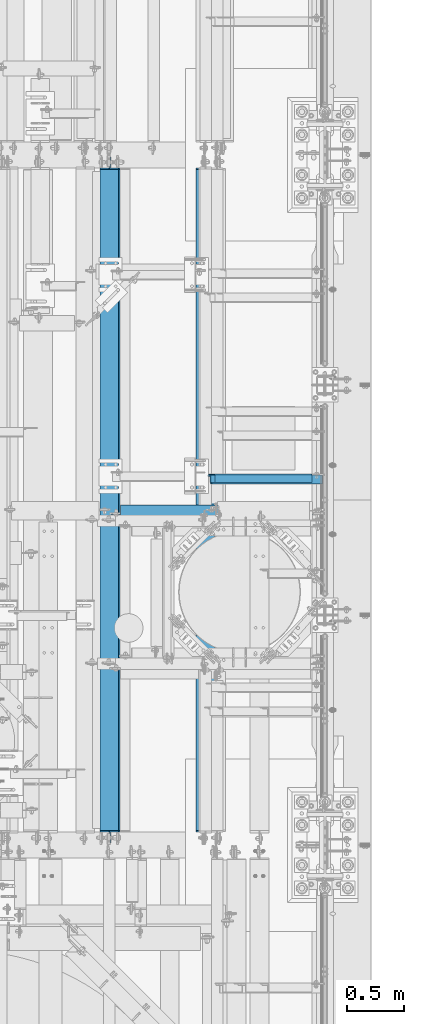
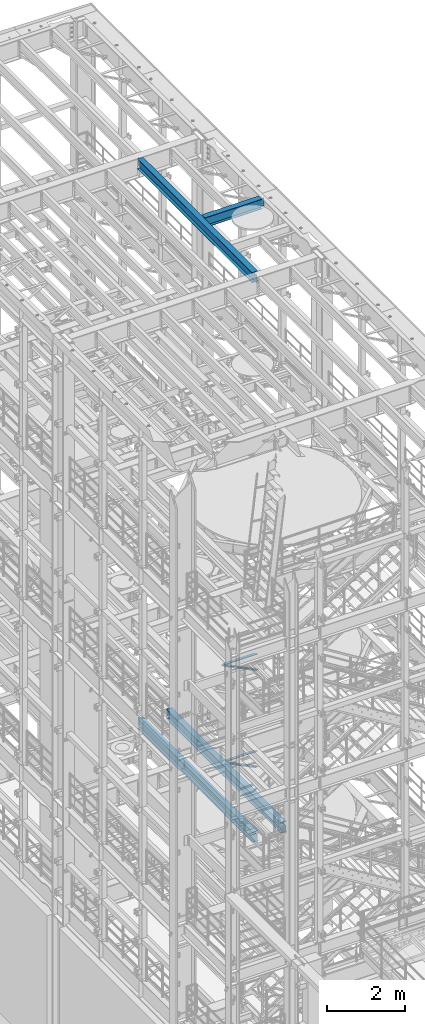
# One storey, part 1032 of 1876: 6 beams, 2 members, 8 elements without a shape of their own.
"""IFC2X3 building model written with IfcOpenShell, lengths in millimetres."""

from ifc_helpers import new_model, si_unit, frame, origin_with_axes, place, context, subcontext, project, spatial, faceted_brep, material, type_object, element, aggregate, save


model = new_model("IFC2X3")

# Units and contexts
model_context = context("Model", 3, precision=1e-05, world=origin_with_axes())
body_context = subcontext(model_context, "Body", "Model", "MODEL_VIEW")
ifc_project = project(units=[si_unit("LENGTHUNIT", "METRE", prefix="MILLI"), si_unit("AREAUNIT", "SQUARE_METRE"), si_unit("VOLUMEUNIT", "CUBIC_METRE"), si_unit("MASSUNIT", "GRAM", prefix="KILO"), si_unit("TIMEUNIT", "SECOND"), si_unit("PLANEANGLEUNIT", "RADIAN"), si_unit("SOLIDANGLEUNIT", "STERADIAN"), si_unit("THERMODYNAMICTEMPERATUREUNIT", "DEGREE_CELSIUS"), si_unit("LUMINOUSINTENSITYUNIT", "LUMEN")], contexts=[model_context])

# Site, building, storey
site_placement = place(None, origin_with_axes())
site = spatial("IfcSite", under=ifc_project, at=site_placement, CompositionType="ELEMENT")
building_placement = place(site_placement, origin_with_axes())
building = spatial("IfcBuilding", under=site, at=building_placement, Name="Undefined", CompositionType="ELEMENT")
storey_placement = place(building_placement, origin_with_axes())
storey = spatial("IfcBuildingStorey", under=building, at=storey_placement, Name="Undefined", CompositionType="ELEMENT", Elevation=0.0)

# Assembly, member
assembly_1_placement = place(storey_placement, origin_with_axes())
assembly_1 = element("IfcElementAssembly", 1, at=assembly_1_placement, inside=storey, AssemblyPlace="NOTDEFINED", PredefinedType="RIGID_FRAME")
ifc_material_1 = material(Name="STEEL/A36")
member_type = type_object("IfcMemberType", Name="L3X3X3/8", PredefinedType="NOTDEFINED")
member_1_placement = place(assembly_1_placement, frame((6549.21887719362, 4752.975, 5096.54580110531), z_axis=(0.0, -1.0, 0.0), x_axis=(0.899060338191213, 0.0, -0.437824746093117)))
member_1 = element("IfcMember", 2, at=member_1_placement, type_object=member_type, material=ifc_material_1, ObjectType="L3X3X3/8", context=body_context, shape_type="Brep", body=[
    faceted_brep([(54.7652293632691, 38.0999999999885, -38.1000000000004), (54.7652293632691, 38.0999999999885, 38.1000000000004), (1150.37468125874, 38.1000000001977, 38.1000000000004), (1150.37468125874, 38.1000000001977, -38.1000000000004), (54.7652293632686, 28.5749999999944, 38.1000000000004), (1150.37468125873, 28.5750000002035, 38.1000000000004), (54.7652293632686, 28.5749999999944, -28.5749999999998), (1150.37468125873, 28.5750000002035, -28.5749999999998), (54.7652293632682, -38.0999999999685, -28.5749999999998), (1150.37468125873, -38.0999999997593, -28.5749999999998), (54.7652293632682, -38.0999999999685, -38.1000000000004), (1150.37468125873, -38.0999999997593, -38.1000000000004)], [[[0, 1, 2, 3]], [[1, 4, 5, 2]], [[4, 6, 7, 5]], [[6, 8, 9, 7]], [[8, 10, 11, 9]], [[10, 0, 3, 11]], [[5, 7, 9, 11, 3, 2]], [[10, 8, 6, 4, 1, 0]]]),
])
aggregate(assembly_1, [member_1])

assembly_2_placement = place(storey_placement, origin_with_axes())
assembly_2 = element("IfcElementAssembly", 3, at=assembly_2_placement, inside=storey, AssemblyPlace="NOTDEFINED", PredefinedType="RIGID_FRAME")
member_2_placement = place(assembly_2_placement, frame((6536.16116201617, 4752.975, 8132.02232402439), z_axis=(0.0, -1.0, 0.0), x_axis=(0.894427191199916, 0.0, -0.447213595099958)))
member_2 = element("IfcMember", 4, at=member_2_placement, type_object=member_type, material=ifc_material_1, ObjectType="L3X3X3/8", context=body_context, shape_type="Brep", body=[
    faceted_brep([(78.0946740306676, 38.1000000000076, -38.0999999999999), (78.0946740306676, 38.1000000000076, 38.0999999999999), (1170.5326724749, 38.0999999997912, 38.0999999999999), (1170.5326724749, 38.0999999997912, -38.0999999999999), (78.0946740306676, 28.5750000000025, 38.0999999999999), (1170.5326724749, 28.5749999997861, 38.0999999999999), (78.0946740306676, 28.5750000000025, -28.5749999999998), (1170.5326724749, 28.5749999997861, -28.5749999999998), (78.0946740306667, -38.1000000000367, -28.5749999999998), (1170.5326724749, -38.1000000002532, -28.5749999999998), (78.0946740306667, -38.1000000000367, -38.0999999999999), (1170.5326724749, -38.1000000002532, -38.0999999999999)], [[[0, 1, 2, 3]], [[1, 4, 5, 2]], [[4, 6, 7, 5]], [[6, 8, 9, 7]], [[8, 10, 11, 9]], [[10, 0, 3, 11]], [[5, 7, 9, 11, 3, 2]], [[10, 8, 6, 4, 1, 0]]]),
])
aggregate(assembly_2, [member_2])

# Assembly, beam
assembly_3_placement = place(storey_placement, origin_with_axes())
assembly_3 = element("IfcElementAssembly", 5, at=assembly_3_placement, inside=storey, Name="BEAM", AssemblyPlace="NOTDEFINED", PredefinedType="RIGID_FRAME")
ifc_material_2 = material(Name="STEEL/A992")
beam_type_1 = type_object("IfcBeamType", Name="W12X26", PredefinedType="NOTDEFINED")
beam_1_placement = place(assembly_3_placement, frame((5715.0, 4444.99920043945, 22399.625), z_axis=(0.0, 0.0, 1.0), x_axis=(1.0, 0.0, 0.0)))
beam_1 = element("IfcBeam", 6, at=beam_1_placement, type_object=beam_type_1, material=ifc_material_2, Name="BEAM", ObjectType="W12X26", context=body_context, shape_type="Brep", body=[
    faceted_brep([(1789.90625, -3.17500000000018, -146.049999999999), (1789.90625, -82.5500000000002, -146.049999999999), (1789.90625, -82.5500000000002, -155.575000000001), (1789.90625, 82.5500000000002, -155.575000000001), (1789.90625, 82.5500000000002, -146.049999999999), (1789.90625, 3.17500000000018, -146.049999999999), (1789.90625, 3.17500000000018, -142.874999809264), (1789.90625, -3.17500000000018, -142.874999809264), (1790.87297992259, 3.17500000000018, -138.014920291218), (1790.87297992259, -3.17500000000018, -138.014920291218), (1793.62599382307, 3.17500000000018, -133.894743823064), (1793.62599382307, -3.17500000000018, -133.894743823064), (1797.74617029122, 3.17500000000018, -131.141729922587), (1797.74617029122, -3.17500000000018, -131.141729922587), (1802.60624980926, 3.17500000000018, -130.174999999999), (1802.60624980926, -3.17500000000018, -130.174999999999), (1885.15625, -3.17500000000018, -130.174999999999), (1885.15625, 3.17500000000018, -130.174999999999), (98.4250000000029, 3.17500000000018, 146.049999999999), (98.4250000000002, 82.5500000000002, 146.049999999999), (1777.20625, 82.5500000000002, 146.049999999999), (1777.20625, 3.17500000000018, 146.049999999999), (98.4250000000002, -3.17500000000018, -142.874999809268), (98.4250000000002, 3.17500000000018, -142.874999809268), (98.4250000000029, 3.17500000000018, -146.049999999999), (98.4250000000002, 82.5500000000002, -146.049999999999), (98.4250000000002, 82.5500000000002, -155.575000000001), (98.4250000000002, -82.5500000000002, -155.575000000001), (98.4250000000002, -82.5500000000002, -146.049999999999), (98.4250000000029, -3.17500000000018, -146.049999999999), (97.4582700774126, -3.17500000000018, -138.014920291222), (97.4582700774126, 3.17500000000018, -138.014920291222), (94.7052561769342, -3.17500000000018, -133.894743823068), (94.7052561769342, 3.17500000000018, -133.894743823068), (90.5850797087805, -3.17500000000018, -131.14172992259), (90.5850797087805, 3.17500000000018, -131.14172992259), (85.725000190735, -3.17500000000018, -130.175000000003), (85.725000190735, 3.17500000000018, -130.175000000003), (15.875, -3.17500000000018, -130.175000000003), (15.875, 3.17500000000018, -130.175000000003), (15.875, -3.17500000000018, 117.474999999999), (15.875, 3.17500000000018, 117.474999999999), (85.725000190735, -3.17500000000018, 117.474999999999), (85.725000190735, 3.17500000000018, 117.474999999999), (90.5850797087805, -3.17500000000018, 118.441729922586), (90.5850797087805, 3.17500000000018, 118.441729922586), (94.7052561769342, -3.17500000000018, 121.194743823064), (94.7052561769342, 3.17500000000018, 121.194743823064), (97.4582700774126, -3.17500000000018, 125.314920291217), (97.4582700774126, 3.17500000000018, 125.314920291217), (98.4250000000002, -3.17500000000018, 130.174999809264), (98.4250000000002, 3.17500000000018, 130.174999809264), (98.4250000000002, -82.5500000000002, 155.575000000001), (98.4250000000002, 82.5500000000002, 155.575000000001), (98.4250000000029, -3.17500000000018, 146.049999999999), (98.4250000000002, -82.5500000000002, 146.049999999999), (1777.20625, -3.17500000000018, 146.049999999999), (1777.20625, -82.5500000000002, 146.049999999999), (1777.20625, -82.5500000000002, 155.575000000001), (1777.20625, 82.5500000000002, 155.575000000001), (1777.20625, -3.17500000000018, 130.174999809267), (1777.20625, 3.17500000000018, 130.174999809267), (1778.17297992259, -3.17500000000018, 125.314920291221), (1778.17297992259, 3.17500000000018, 125.314920291221), (1780.92599382307, -3.17500000000018, 121.194743823067), (1780.92599382307, 3.17500000000018, 121.194743823067), (1785.04617029122, -3.17500000000018, 118.44172992259), (1785.04617029122, 3.17500000000018, 118.44172992259), (1789.90624980926, -3.17500000000018, 117.475000000002), (1789.90624980926, 3.17500000000018, 117.475000000002), (1885.15625, -3.17500000000018, 117.475000000002), (1885.15625, 3.17500000000018, 117.475000000002)], [[[0, 1, 2, 3, 4, 5, 6, 7]], [[7, 6, 8, 9]], [[9, 8, 10, 11]], [[11, 10, 12, 13]], [[13, 12, 14, 15]], [[16, 15, 14, 17]], [[18, 19, 20, 21]], [[22, 23, 24, 25, 26, 27, 28, 29]], [[30, 31, 23, 22]], [[32, 33, 31, 30]], [[34, 35, 33, 32]], [[36, 37, 35, 34]], [[38, 39, 37, 36]], [[40, 41, 39, 38]], [[42, 43, 41, 40]], [[44, 45, 43, 42]], [[46, 47, 45, 44]], [[48, 49, 47, 46]], [[50, 51, 49, 48]], [[52, 53, 19, 18, 51, 50, 54, 55]], [[55, 54, 56, 57]], [[52, 55, 57, 58]], [[53, 52, 58, 59]], [[19, 53, 59, 20]], [[58, 57, 56, 60, 61, 21, 20, 59]], [[62, 63, 61, 60]], [[64, 65, 63, 62]], [[66, 67, 65, 64]], [[68, 69, 67, 66]], [[70, 71, 69, 68]], [[71, 70, 16, 17]], [[12, 10, 8, 6, 5, 24, 23, 31, 33, 35, 37, 39, 41, 43, 45, 47, 49, 51, 18, 21, 61, 63, 65, 67, 69, 71, 17, 14]], [[25, 24, 5, 4]], [[26, 25, 4, 3]], [[27, 26, 3, 2]], [[28, 27, 2, 1]], [[29, 28, 1, 0]], [[70, 68, 66, 64, 62, 60, 56, 54, 50, 48, 46, 44, 42, 40, 38, 36, 34, 32, 30, 22, 29, 0, 7, 9, 11, 13, 15, 16]]]),
])
aggregate(assembly_3, [beam_1])

assembly_4_placement = place(storey_placement, origin_with_axes())
assembly_4 = element("IfcElementAssembly", 7, at=assembly_4_placement, inside=storey, Name="BEAM", AssemblyPlace="NOTDEFINED", PredefinedType="RIGID_FRAME")
beam_2_placement = place(assembly_4_placement, frame((5715.0, 1524.0, 22399.625), z_axis=(0.0, 0.0, 1.0), x_axis=(0.0, 1.0, 0.0)))
beam_2 = element("IfcBeam", 8, at=beam_2_placement, type_object=beam_type_1, material=ifc_material_2, Name="BEAM", ObjectType="W12X26", context=body_context, shape_type="Brep", body=[
    faceted_brep([(19.8437512414296, -3.17500000000109, -130.175), (19.8437487585795, 3.17499999999927, -130.175), (102.393750190735, 3.17500000000018, -130.174999999999), (102.393750190735, -3.17500000000018, -130.174999999999), (107.25382970878, 3.17500000000018, -131.141729922587), (107.25382970878, -3.17500000000018, -131.141729922587), (111.374006176934, 3.17500000000018, -133.894743823064), (111.374006176934, -3.17500000000018, -133.894743823064), (114.127020077412, 3.17500000000018, -138.014920291218), (114.127020077412, -3.17500000000018, -138.014920291218), (115.09375, -3.17500000000018, -142.874999809264), (115.09375, 3.17500000000018, -142.874999809264), (115.09375, 3.17500000000018, -146.05), (115.09375, 82.5500000000002, -146.05), (115.09375, 82.5500000000002, -155.575000000001), (115.09375, -82.5500000000002, -155.575000000001), (115.09375, -82.5500000000002, -146.05), (115.09375, -3.17500000000018, -146.05), (5968.20624911051, 82.55, 146.049999999999), (5968.20625, 3.17499999999995, 146.05), (127.79375, 3.17500000000018, 146.05), (127.793782276814, 82.5500000000102, 146.05), (115.09378246755, -3.17499999999654, 117.474999999999), (115.093782467549, 3.17500000000382, 117.474999999999), (19.8437487585795, 3.17499999999927, 117.474999999999), (19.8437512414296, -3.17500000000109, 117.474999999999), (119.953861985596, -3.17499999999654, 118.441729922587), (119.953861985596, 3.17500000000382, 118.441729922587), (124.074038453751, -3.17499999999654, 121.194743823065), (124.074038453751, 3.17500000000382, 121.194743823065), (126.82705235423, -3.17499999999654, 125.314920291219), (126.827052354229, 3.17500000000473, 125.314920291219), (127.793782276818, -3.17499999999654, 130.174999809265), (127.793782276817, 3.17500000000382, 130.174999809265), (5968.20625, -82.5500000000002, 155.575000000001), (5968.20625, 82.5500000000002, 155.575000000001), (127.793782276814, 82.5500000000102, 155.575), (127.793782276821, -82.5500000000029, 155.575), (5968.20624911051, -82.55, 146.049999999999), (127.793782276821, -82.5500000000029, 146.05), (5968.20625, -3.17499999999995, 146.05), (127.79375, -3.17500000000018, 146.05), (5968.20625, -3.17500000000018, 130.174999809267), (5968.20625, 3.17500000000018, 130.174999809267), (5969.17297992259, -3.17500000000018, 125.314920291221), (5969.17297992259, 3.17500000000018, 125.314920291221), (5971.92599382307, -3.17500000000018, 121.194743823067), (5971.92599382307, 3.17500000000018, 121.194743823067), (5976.04617029122, -3.17500000000018, 118.44172992259), (5976.04617029122, 3.17500000000018, 118.44172992259), (5980.90624980927, -3.17500000000018, 117.475000000002), (5980.90624980927, 3.17500000000018, 117.475000000002), (6076.15625, -3.17500000000018, 117.475000000002), (6076.15625, 3.17500000000018, 117.475000000002), (6076.15625, -3.17499999999995, -130.174999999996), (6076.15625, 3.17499999999995, -130.174999999996), (5993.60624980927, -3.17500000000018, -130.174999999999), (5993.60624980927, 3.17500000000018, -130.174999999999), (5988.74617029122, -3.17500000000018, -131.141729922587), (5988.74617029122, 3.17500000000018, -131.141729922587), (5984.62599382307, -3.17500000000018, -133.894743823064), (5984.62599382307, 3.17500000000018, -133.894743823064), (5981.87297992259, -3.17500000000018, -138.014920291218), (5981.87297992259, 3.17500000000018, -138.014920291218), (5980.90625, -3.17500000000018, -142.874999809264), (5980.90625, 3.17500000000018, -142.874999809264), (5980.90625, -3.17499999999995, -146.05), (5980.90625, -82.5500000000002, -146.049999999999), (5980.90625, -82.5500000000002, -155.575000000001), (5980.90625, 82.5500000000002, -155.575000000001), (5980.90625, 82.5500000000002, -146.049999999999), (5980.90625, 3.17499999999995, -146.05)], [[[0, 1, 2, 3]], [[3, 2, 4, 5]], [[5, 4, 6, 7]], [[7, 6, 8, 9]], [[10, 11, 12, 13, 14, 15, 16, 17]], [[9, 8, 11, 10]], [[18, 19, 20, 21]], [[22, 23, 24, 25]], [[26, 27, 23, 22]], [[28, 29, 27, 26]], [[30, 31, 29, 28]], [[32, 33, 31, 30]], [[34, 35, 36, 37]], [[38, 34, 37, 39]], [[40, 38, 39, 41]], [[37, 36, 21, 20, 33, 32, 41, 39]], [[35, 18, 21, 36]], [[34, 38, 40, 42, 43, 19, 18, 35]], [[44, 45, 43, 42]], [[46, 47, 45, 44]], [[48, 49, 47, 46]], [[50, 51, 49, 48]], [[52, 53, 51, 50]], [[53, 52, 54, 55]], [[54, 56, 57, 55]], [[58, 59, 57, 56]], [[60, 61, 59, 58]], [[62, 63, 61, 60]], [[64, 65, 63, 62]], [[66, 67, 68, 69, 70, 71, 65, 64]], [[67, 66, 17, 16]], [[68, 67, 16, 15]], [[69, 68, 15, 14]], [[70, 69, 14, 13]], [[71, 70, 13, 12]], [[6, 4, 2, 1, 24, 23, 27, 29, 31, 33, 20, 19, 43, 45, 47, 49, 51, 53, 55, 57, 59, 61, 63, 65, 71, 12, 11, 8]], [[25, 24, 1, 0]], [[66, 64, 62, 60, 58, 56, 54, 52, 50, 48, 46, 44, 42, 40, 41, 32, 30, 28, 26, 22, 25, 0, 3, 5, 7, 9, 10, 17]]]),
])
aggregate(assembly_4, [beam_2])

assembly_5_placement = place(storey_placement, origin_with_axes())
assembly_5 = element("IfcElementAssembly", 9, at=assembly_5_placement, inside=storey, Name="ANGLE", AssemblyPlace="NOTDEFINED", PredefinedType="RIGID_FRAME")
beam_type_2 = type_object("IfcBeamType", Name="L3X3X3/8", PredefinedType="NOTDEFINED")
beam_3_placement = place(assembly_5_placement, frame((6553.19999999857, 4762.5, 8115.3), z_axis=(0.0, -1.0, 0.0), x_axis=(1.0, 0.0, 0.0)))
beam_3 = element("IfcBeam", 10, at=beam_3_placement, type_object=beam_type_2, material=ifc_material_1, Name="ANGLE", ObjectType="L3X3X3/8", context=body_context, shape_type="Brep", body=[
    faceted_brep([(950.913000303442, 28.5749999999998, -28.5749999999998), (950.913001170238, 28.5749999999998, 38.0999999999999), (52.3870335430847, 28.5750001907327, 38.0999999999858), (52.3869956588824, 28.5749999999955, -28.5750000000007), (950.913001170238, 38.1000000000004, 38.0999999999999), (52.387033543122, 38.0999999999985, 38.0999999999858), (15.8749936676099, 28.5749999999989, -28.5750000000007), (15.8749999382144, 28.5750001907327, -38.0999999999999), (3.17500012894925, 15.8750003814675, -38.0999999999999), (3.17500032897624, 15.8750003814675, -28.5749999999998), (52.3870393343063, 28.5750001907327, -38.1000000000149), (52.3869953826566, 38.0999999999954, -38.0999999999985), (950.913000179614, 38.1000000000004, -38.0999999999999), (950.913000303442, 12.6999992370611, -28.5749999999998), (950.913000179614, 12.6999992370611, -38.0999999999999), (1027.90624828928, 12.6999992370611, -28.5749999999998), (1027.90624816545, 12.6999992370611, -38.0999999999999), (1059.65624828928, -19.0500007629389, -28.5749999999998), (1059.65624816545, -19.0500007629389, -38.0999999999999), (1059.65625000143, -38.1000000000004, -28.5749999999998), (1059.65625000143, -38.1000000000004, -38.0999999999999), (3.17499999075153, -38.0999999999985, -28.5749999999998), (3.17499999075153, -38.0999999999985, -38.0999999999999), (3.17500012894925, 3.17500152587672, -38.0999999999999), (3.17500032897624, 3.17500152587672, -28.5749999999998)], [[[0, 1, 2, 3]], [[1, 4, 5, 2]], [[6, 7, 8, 9]], [[3, 10, 7, 6]], [[2, 5, 11, 10, 3]], [[4, 12, 11, 5]], [[1, 0, 13, 14, 12, 4]], [[15, 16, 14, 13]], [[16, 15, 17, 18]], [[18, 17, 19, 20]], [[20, 19, 21, 22]], [[8, 7, 10, 11, 12, 14, 16, 18, 20, 22, 23]], [[9, 8, 23, 24]], [[19, 17, 15, 13, 0, 3, 6, 9, 24, 21]], [[23, 22, 21, 24]]]),
])
aggregate(assembly_5, [beam_3])

assembly_6_placement = place(storey_placement, origin_with_axes())
assembly_6 = element("IfcElementAssembly", 11, at=assembly_6_placement, inside=storey, Name="ANGLE", AssemblyPlace="NOTDEFINED", PredefinedType="RIGID_FRAME")
beam_4_placement = place(assembly_6_placement, frame((6489.7, 4762.5, 5092.7), z_axis=(0.0, -1.0, 0.0), x_axis=(1.0, 0.0, 0.0)))
beam_4 = element("IfcBeam", 12, at=beam_4_placement, type_object=beam_type_2, material=ifc_material_1, Name="ANGLE", ObjectType="L3X3X3/8", context=body_context, shape_type="Brep", body=[
    faceted_brep([(1014.41300030201, 28.5749999999998, -28.5749999999998), (1014.41300116881, 28.5749999999998, 38.1000000000004), (160.337055571042, 28.5749999999998, 38.1000000000004), (160.337055570792, 28.5749999999998, -28.5749999999998), (1014.41300116881, 38.1000000000004, 38.1000000000004), (160.337388892724, 38.1000000000004, 38.1000000000004), (98.4249977111795, 26.9870083759042, -28.5749999999998), (98.4249977111795, 26.9870093950822, -38.1000000000004), (79.3749984741189, 7.93701015802071, -38.1000000000004), (79.3749984741189, 7.93700913884368, -28.5749999999998), (160.336999999974, 26.9870083759042, -28.5749999999998), (160.336999999974, 26.9870093950822, -38.1000000000004), (160.337388892438, 38.1000000000004, -38.1000000000004), (1014.41300017818, 38.1000000000004, -38.1000000000004), (1014.41300030201, 12.6999992370611, -28.5749999999998), (1014.41300017818, 12.6999992370611, -38.1000000000004), (1091.40624828785, 12.6999992370611, -28.5749999999998), (1091.40624816402, 12.6999992370611, -38.1000000000004), (1123.15624828785, -19.0500007629389, -28.5749999999998), (1123.15624816402, -19.0500007629389, -38.1000000000004), (1123.15625, -38.1000000000004, -28.5749999999998), (1123.15625, -38.1000000000004, -38.1000000000004), (79.375, -38.1000000000004, -28.5749999999998), (79.375, -38.1000000000004, -38.1000000000004), (79.3749984741189, 1.58700977655099, -38.1000000000004), (79.3749984741189, 1.58700875737395, -28.5749999999998)], [[[0, 1, 2, 3]], [[1, 4, 5, 2]], [[6, 7, 8, 9]], [[10, 11, 7, 6]], [[2, 5, 12, 11, 10, 3]], [[4, 13, 12, 5]], [[1, 0, 14, 15, 13, 4]], [[16, 17, 15, 14]], [[17, 16, 18, 19]], [[19, 18, 20, 21]], [[21, 20, 22, 23]], [[8, 7, 11, 12, 13, 15, 17, 19, 21, 23, 24]], [[9, 8, 24, 25]], [[20, 18, 16, 14, 0, 3, 10, 6, 9, 25, 22]], [[24, 23, 22, 25]]]),
])
aggregate(assembly_6, [beam_4])

assembly_7_placement = place(storey_placement, origin_with_axes())
assembly_7 = element("IfcElementAssembly", 13, at=assembly_7_placement, inside=storey, Name="BEAM", AssemblyPlace="NOTDEFINED", PredefinedType="RIGID_FRAME")
beam_type_3 = type_object("IfcBeamType", Name="W12X30", PredefinedType="NOTDEFINED")
beam_5_placement = place(assembly_7_placement, frame((6565.9, 1524.0, 4973.6375), z_axis=(0.0, 0.0, 1.0), x_axis=(0.0, 1.0, 0.0)))
beam_5 = element("IfcBeam", 14, at=beam_5_placement, type_object=beam_type_3, material=ifc_material_2, Name="BEAM", ObjectType="W12X30", context=body_context, shape_type="Brep", body=[
    faceted_brep([(19.8437500000002, -3.17500000000018, -131.762499999993), (19.8437500000002, 3.17500000000018, -131.762499999993), (102.393750190735, 3.17500000000018, -131.762500000001), (102.393750190735, -3.17500000000018, -131.762500000001), (107.25382970878, 3.17500000000018, -132.729229922588), (107.25382970878, -3.17500000000018, -132.729229922588), (111.374006176934, 3.17500000000018, -135.482243823067), (111.374006176934, -3.17500000000018, -135.482243823067), (114.127020077412, 3.17500000000018, -139.60242029122), (114.127020077412, -3.17500000000018, -139.60242029122), (115.09375, -3.17500000000018, -144.462499809266), (115.09375, 3.17500000000018, -144.462499809266), (115.09375, 3.17500000000018, -146.05), (115.09375, 82.5500000000002, -146.05), (115.09375, 82.5500000000002, -157.1625), (115.09375, -82.5500000000002, -157.1625), (115.09375, -82.5500000000002, -146.05), (115.09375, -3.17500000000018, -146.05), (5968.20624911051, 82.55, 146.049999999999), (5968.20625, 3.17499999999995, 146.05), (127.79375, 3.17500000000018, 146.05), (127.793782276814, 82.5500000000102, 146.05), (115.09374930124, -3.17499999999995, 119.062500000004), (115.09374930124, 3.17499999999995, 119.062500000004), (19.8437491105051, 3.17499999999995, 119.062500000004), (19.8437491105051, -3.17499999999995, 119.062500000004), (119.953828819285, -3.17499999999995, 120.029229922591), (119.953828819285, 3.17499999999995, 120.029229922591), (124.074005287439, -3.17499999999995, 122.782243823069), (124.074005287439, 3.17499999999995, 122.782243823069), (126.827019187917, -3.17499999999995, 126.902420291222), (126.827019187917, 3.17499999999995, 126.902420291222), (127.793749110505, -3.17499999999995, 131.762499809269), (127.793749110505, 3.17499999999995, 131.762499809269), (5968.20624911051, -82.55, 157.162499999999), (5968.20624911051, 82.55, 157.162499999999), (127.793749110505, 82.55, 157.162499999999), (127.793749110505, -82.55, 157.162499999999), (5968.20624911051, -82.55, 146.049999999999), (127.793782276821, -82.5500000000029, 146.05), (5968.20625, -3.17499999999995, 146.05), (127.79375, -3.17500000000018, 146.05), (5968.20624911051, -3.17499999999995, 131.762499809269), (5968.20624911051, 3.17499999999995, 131.762499809269), (5969.17297903309, -3.17499999999995, 126.902420291222), (5969.17297903309, 3.17499999999995, 126.902420291222), (5971.92599293357, -3.17499999999995, 122.782243823069), (5971.92599293357, 3.17499999999995, 122.782243823069), (5976.04616940172, -3.17499999999995, 120.029229922591), (5976.04616940172, 3.17499999999995, 120.029229922591), (5980.90624891977, -3.17499999999995, 119.062500000004), (5980.90624891977, 3.17499999999995, 119.062500000004), (6076.15624911051, -3.17499999999995, 119.062500000004), (6076.15624911051, 3.17499999999995, 119.062500000004), (6076.15625, -3.17500000000018, -131.762499999993), (6076.15625, 3.17500000000018, -131.762499999993), (5993.60624980927, -3.17500000000018, -131.762500000001), (5993.60624980927, 3.17500000000018, -131.762500000001), (5988.74617029122, -3.17500000000018, -132.729229922588), (5988.74617029122, 3.17500000000018, -132.729229922588), (5984.62599382307, -3.17500000000018, -135.482243823067), (5984.62599382307, 3.17500000000018, -135.482243823067), (5981.87297992259, -3.17500000000018, -139.60242029122), (5981.87297992259, 3.17500000000018, -139.60242029122), (5980.90625, -3.17500000000018, -144.462499809266), (5980.90625, 3.17500000000018, -144.462499809266), (5980.90625, -3.17499999999995, -146.05), (5980.90625, -82.5500000000002, -146.049999999999), (5980.90625, -82.5500000000002, -157.1625), (5980.90625, 82.5500000000002, -157.1625), (5980.90625, 82.5500000000002, -146.049999999999), (5980.90625, 3.17499999999995, -146.05)], [[[0, 1, 2, 3]], [[3, 2, 4, 5]], [[5, 4, 6, 7]], [[7, 6, 8, 9]], [[10, 11, 12, 13, 14, 15, 16, 17]], [[9, 8, 11, 10]], [[18, 19, 20, 21]], [[22, 23, 24, 25]], [[26, 27, 23, 22]], [[28, 29, 27, 26]], [[30, 31, 29, 28]], [[32, 33, 31, 30]], [[34, 35, 36, 37]], [[38, 34, 37, 39]], [[40, 38, 39, 41]], [[37, 36, 21, 20, 33, 32, 41, 39]], [[35, 18, 21, 36]], [[34, 38, 40, 42, 43, 19, 18, 35]], [[44, 45, 43, 42]], [[46, 47, 45, 44]], [[48, 49, 47, 46]], [[50, 51, 49, 48]], [[52, 53, 51, 50]], [[53, 52, 54, 55]], [[54, 56, 57, 55]], [[58, 59, 57, 56]], [[60, 61, 59, 58]], [[62, 63, 61, 60]], [[64, 65, 63, 62]], [[66, 67, 68, 69, 70, 71, 65, 64]], [[67, 66, 17, 16]], [[68, 67, 16, 15]], [[69, 68, 15, 14]], [[70, 69, 14, 13]], [[71, 70, 13, 12]], [[6, 4, 2, 1, 24, 23, 27, 29, 31, 33, 20, 19, 43, 45, 47, 49, 51, 53, 55, 57, 59, 61, 63, 65, 71, 12, 11, 8]], [[25, 24, 1, 0]], [[66, 64, 62, 60, 58, 56, 54, 52, 50, 48, 46, 44, 42, 40, 41, 32, 30, 28, 26, 22, 25, 0, 3, 5, 7, 9, 10, 17]]]),
])
aggregate(assembly_7, [beam_5])

assembly_8_placement = place(storey_placement, origin_with_axes())
assembly_8 = element("IfcElementAssembly", 15, at=assembly_8_placement, inside=storey, Name="BEAM", AssemblyPlace="NOTDEFINED", PredefinedType="RIGID_FRAME")
beam_6_placement = place(assembly_8_placement, frame((5727.7, 1524.0, 4973.6375), z_axis=(0.0, 0.0, 1.0), x_axis=(0.0, 1.0, 0.0)))
beam_6 = element("IfcBeam", 16, at=beam_6_placement, type_object=beam_type_3, material=ifc_material_2, Name="BEAM", ObjectType="W12X30", context=body_context, shape_type="Brep", body=[
    faceted_brep([(19.8437500000002, -3.17500000000018, -131.762499999993), (19.8437500000002, 3.17500000000018, -131.762499999993), (102.393750190735, 3.17500000000018, -131.762500000001), (102.393750190735, -3.17500000000018, -131.762500000001), (107.25382970878, 3.17500000000018, -132.729229922588), (107.25382970878, -3.17500000000018, -132.729229922588), (111.374006176934, 3.17500000000018, -135.482243823067), (111.374006176934, -3.17500000000018, -135.482243823067), (114.127020077412, 3.17500000000018, -139.60242029122), (114.127020077412, -3.17500000000018, -139.60242029122), (115.09375, -3.17500000000018, -144.462499809266), (115.09375, 3.17500000000018, -144.462499809266), (115.09375, 3.17500000000018, -146.05), (115.09375, 82.5500000000002, -146.05), (115.09375, 82.5500000000002, -157.1625), (115.09375, -82.5500000000002, -157.1625), (115.09375, -82.5500000000002, -146.05), (115.09375, -3.17500000000018, -146.05), (5968.20624911051, 82.55, 146.049999999999), (5968.20625, 3.17499999999995, 146.05), (127.79375, 3.17500000000018, 146.05), (127.793782276814, 82.5500000000102, 146.05), (115.09374930124, -3.17499999999995, 119.062500000004), (115.09374930124, 3.17499999999995, 119.062500000004), (19.8437491105051, 3.17499999999995, 119.062500000004), (19.8437491105051, -3.17499999999995, 119.062500000004), (119.953828819285, -3.17499999999995, 120.029229922591), (119.953828819285, 3.17499999999995, 120.029229922591), (124.074005287439, -3.17499999999995, 122.782243823069), (124.074005287439, 3.17499999999995, 122.782243823069), (126.827019187917, -3.17499999999995, 126.902420291222), (126.827019187917, 3.17499999999995, 126.902420291222), (127.793749110505, -3.17499999999995, 131.762499809269), (127.793749110505, 3.17499999999995, 131.762499809269), (5968.20624911051, -82.55, 157.162499999999), (5968.20624911051, 82.55, 157.162499999999), (127.793749110505, 82.55, 157.162499999999), (127.793749110505, -82.55, 157.162499999999), (5968.20624911051, -82.55, 146.049999999999), (127.793782276821, -82.5500000000029, 146.05), (5968.20625, -3.17499999999995, 146.05), (127.79375, -3.17500000000018, 146.05), (5968.20624911051, -3.17499999999995, 131.762499809269), (5968.20624911051, 3.17499999999995, 131.762499809269), (5969.17297903309, -3.17499999999995, 126.902420291222), (5969.17297903309, 3.17499999999995, 126.902420291222), (5971.92599293357, -3.17499999999995, 122.782243823069), (5971.92599293357, 3.17499999999995, 122.782243823069), (5976.04616940172, -3.17499999999995, 120.029229922591), (5976.04616940172, 3.17499999999995, 120.029229922591), (5980.90624891977, -3.17499999999995, 119.062500000004), (5980.90624891977, 3.17499999999995, 119.062500000004), (6076.15624911051, -3.17499999999995, 119.062500000004), (6076.15624911051, 3.17499999999995, 119.062500000004), (6076.15625, -3.17500000000018, -131.762499999993), (6076.15625, 3.17500000000018, -131.762499999993), (5993.60624980927, -3.17500000000018, -131.762500000001), (5993.60624980927, 3.17500000000018, -131.762500000001), (5988.74617029122, -3.17500000000018, -132.729229922588), (5988.74617029122, 3.17500000000018, -132.729229922588), (5984.62599382307, -3.17500000000018, -135.482243823067), (5984.62599382307, 3.17500000000018, -135.482243823067), (5981.87297992259, -3.17500000000018, -139.60242029122), (5981.87297992259, 3.17500000000018, -139.60242029122), (5980.90625, -3.17500000000018, -144.462499809266), (5980.90625, 3.17500000000018, -144.462499809266), (5980.90625, -3.17499999999995, -146.05), (5980.90625, -82.5500000000002, -146.049999999999), (5980.90625, -82.5500000000002, -157.1625), (5980.90625, 82.5500000000002, -157.1625), (5980.90625, 82.5500000000002, -146.049999999999), (5980.90625, 3.17499999999995, -146.05)], [[[0, 1, 2, 3]], [[3, 2, 4, 5]], [[5, 4, 6, 7]], [[7, 6, 8, 9]], [[10, 11, 12, 13, 14, 15, 16, 17]], [[9, 8, 11, 10]], [[18, 19, 20, 21]], [[22, 23, 24, 25]], [[26, 27, 23, 22]], [[28, 29, 27, 26]], [[30, 31, 29, 28]], [[32, 33, 31, 30]], [[34, 35, 36, 37]], [[38, 34, 37, 39]], [[40, 38, 39, 41]], [[37, 36, 21, 20, 33, 32, 41, 39]], [[35, 18, 21, 36]], [[34, 38, 40, 42, 43, 19, 18, 35]], [[44, 45, 43, 42]], [[46, 47, 45, 44]], [[48, 49, 47, 46]], [[50, 51, 49, 48]], [[52, 53, 51, 50]], [[53, 52, 54, 55]], [[54, 56, 57, 55]], [[58, 59, 57, 56]], [[60, 61, 59, 58]], [[62, 63, 61, 60]], [[64, 65, 63, 62]], [[66, 67, 68, 69, 70, 71, 65, 64]], [[67, 66, 17, 16]], [[68, 67, 16, 15]], [[69, 68, 15, 14]], [[70, 69, 14, 13]], [[71, 70, 13, 12]], [[6, 4, 2, 1, 24, 23, 27, 29, 31, 33, 20, 19, 43, 45, 47, 49, 51, 53, 55, 57, 59, 61, 63, 65, 71, 12, 11, 8]], [[25, 24, 1, 0]], [[66, 64, 62, 60, 58, 56, 54, 52, 50, 48, 46, 44, 42, 40, 41, 32, 30, 28, 26, 22, 25, 0, 3, 5, 7, 9, 10, 17]]]),
])
aggregate(assembly_8, [beam_6])

save(model, "model.ifc")
